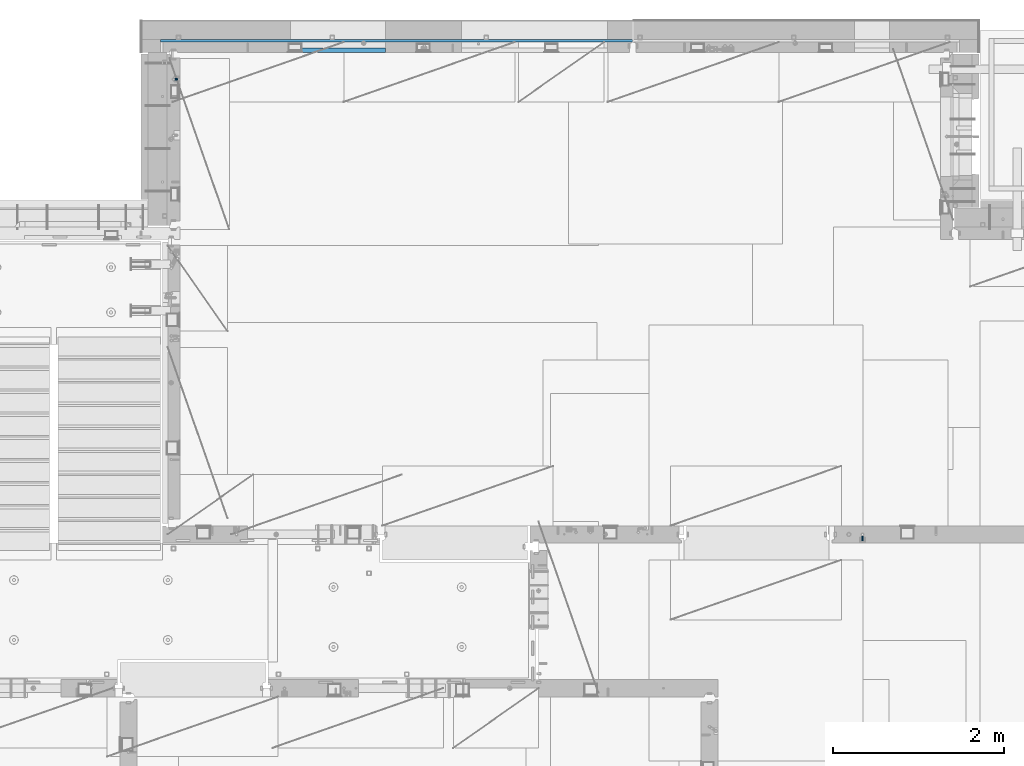
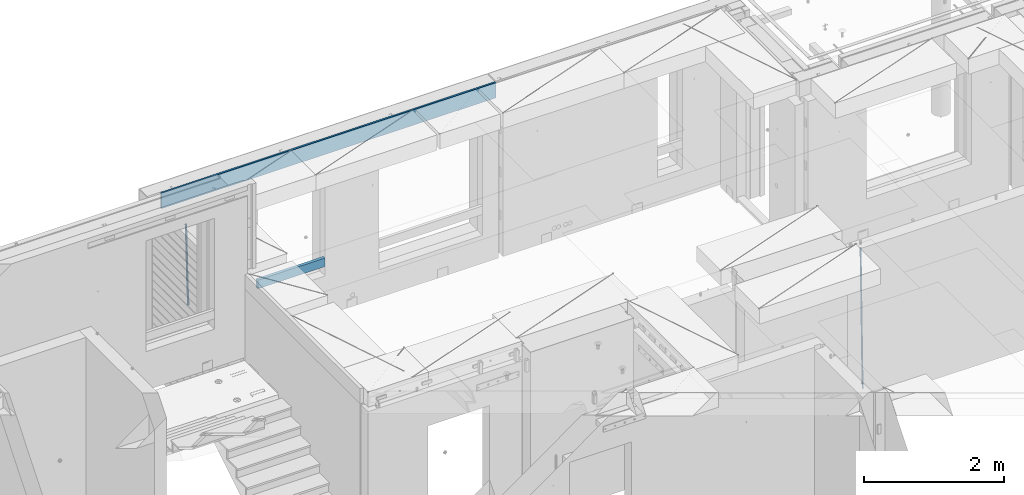
# One storey, part 126 of 349: 4 beams, 3 elements without a shape of their own.
"""IFC2X3 building model written with IfcOpenShell, lengths in millimetres."""

from ifc_helpers import new_model, si_unit, frame, origin_with_axes, place, context, subcontext, project, spatial, faceted_brep, material, type_object, element, aggregate, save


model = new_model("IFC2X3")

# Units and contexts
model_context = context("Model", 3, precision=1e-05, world=origin_with_axes())
body_context = subcontext(model_context, "Body", "Model", "MODEL_VIEW")
ifc_project = project(units=[si_unit("LENGTHUNIT", "METRE", prefix="MILLI"), si_unit("AREAUNIT", "SQUARE_METRE"), si_unit("VOLUMEUNIT", "CUBIC_METRE"), si_unit("MASSUNIT", "GRAM", prefix="KILO"), si_unit("TIMEUNIT", "SECOND"), si_unit("PLANEANGLEUNIT", "RADIAN"), si_unit("SOLIDANGLEUNIT", "STERADIAN"), si_unit("THERMODYNAMICTEMPERATUREUNIT", "DEGREE_CELSIUS"), si_unit("LUMINOUSINTENSITYUNIT", "LUMEN")], contexts=[model_context])

# Site, building, storey
site_placement = place(None, origin_with_axes())
site = spatial("IfcSite", under=ifc_project, at=site_placement, CompositionType="ELEMENT")
building_placement = place(site_placement, origin_with_axes())
building = spatial("IfcBuilding", under=site, at=building_placement, CompositionType="ELEMENT")
storey_placement = place(building_placement, origin_with_axes())
storey = spatial("IfcBuildingStorey", under=building, at=storey_placement, Name="4", CompositionType="ELEMENT", Elevation=0.0)

# Assembly, beam
assembly_1_placement = place(storey_placement, origin_with_axes())
assembly_1 = element("IfcElementAssembly", 1, at=assembly_1_placement, inside=storey, AssemblyPlace="NOTDEFINED", PredefinedType="REINFORCEMENT_UNIT")
ifc_material_1 = material()
beam_type_1 = type_object("IfcBeamType", Name="D20", PredefinedType="NOTDEFINED")
beam_1_placement = place(assembly_1_placement, frame((30400.0000000039, 16915.0002418615, 90990.0), z_axis=(-0.000205762999925498, 0.999642804629538, -0.0267249099901004), x_axis=(4.30000201928125e-08, 0.0267249099948059, 0.999642825806181)))
beam_1 = element("IfcBeam", 2, at=beam_1_placement, type_object=beam_type_1, material=ifc_material_1, Name="JM20", ObjectType="D20", context=body_context, shape_type="Brep", body=[
    faceted_brep([(0.0, -10.0, 0.0), (-4.19531716033816e-08, -7.07106781186667, -7.07106781187031), (60.4266690400545, -7.0710677960451, -7.07106780570757), (60.4266690441291, -9.99999998418934, 6.15546014159918e-09), (0.0, 0.0, -10.0), (60.426669036824, 1.58106558956206e-08, -9.99999999384454), (4.196772351861e-08, 7.07106781186303, -7.07106781186667), (60.4266690363438, 7.07106782768096, -7.07106780570757), (0.0, 10.0, 0.0), (60.4266690388904, 10.0000000158179, 6.15182216279209e-09), (4.196772351861e-08, 7.07106781185939, 7.07106781185939), (60.4266690429649, 7.07106782768096, 7.07106781802577), (0.0, 0.0, 10.0), (60.4266690461809, 1.58179318532348e-08, 10.0000000061555), (-4.19531716033816e-08, -7.07106781187031, 7.07106781185939), (60.4266690466611, -7.07106779605238, 7.07106781802213), (61.0378400410118, -7.07106779588503, -7.07106780564936), (60.991799419251, -9.99999998403655, 6.21366780251265e-09), (61.0569027789461, 1.5985278878361e-08, -9.99999999378269), (61.0378209396877, 7.07106782784831, -7.07106780564936), (60.9917724058905, 10.0000000159635, 6.21366780251265e-09), (60.9457317841297, 7.07106782781193, 7.0710678180767), (60.9266690461809, 1.59488990902901e-08, 10.0000000062028), (60.9457508854539, -7.07106779591413, 7.0710678180767), (61.6489592143771, -7.07106614513759, -7.06310863441468), (61.5568818710308, -9.9999984576425, 0.00735959856683621), (61.6870830769039, 1.71821739058942e-06, -9.99179257185824), (61.6489210170112, 7.07106947854481, -7.06310888312146), (61.556827851804, 10.0000015422847, 0.00735924683976918), (61.4647505084577, 7.07106922979438, 7.07782747982128), (61.4266266459163, 1.36643211590126e-06, 10.0065114172685), (61.464788705809, -7.07106639389531, 7.07782772852806), (176.543135720174, -7.07075579406956, -5.56673531796696), (176.451058376813, -9.99968810657447, 1.50373291501455), (176.581259582701, 0.000312069292704109, -8.49541925541052), (176.543097522794, 7.07137982961285, -5.56673556667374), (176.451004357587, 10.00031189336, 1.50373256329476), (176.35892701424, 7.07137958085514, 8.57420079627263), (176.320803151699, 0.000311717507429421, 11.5028847337162), (176.358965211621, -7.07075604281999, 8.57420104497578), (177.098753836006, -7.07075429323595, -5.55949898843028), (176.98362511232, -9.99968666800123, 1.510669025065), (177.146421932586, 0.000313595905026887, -8.48805862247536), (177.098706077581, 7.07138133041735, -5.55949936166144), (176.983557571715, 10.0003133318824, 1.51066849724157), (176.868428848029, 7.07138095712435, 8.58083651073321), (176.820760751449, 0.000313067976094317, 11.5093961447819), (176.868476606425, -7.07075466652896, 8.58083688396073), (177.654312950661, -7.07075204110879, -5.54863964998367), (177.516135294456, -9.99968450931192, 1.52107783331303), (177.711524267797, 0.000315886711177882, -8.47701274570863), (177.654255632195, 7.07138358250813, -5.54864021007961), (177.516054233929, 10.0003154905207, 1.5210770412159), (177.377876577739, 7.0713830223176, 8.59079452451624), (177.320665260588, 0.000315094497636892, 11.5191676202448), (177.377933896176, -7.07075260129932, 8.59079508461218), (299.499456785634, -7.07025810522464, -3.16697112782276), (299.361279129444, -9.99919057342777, 3.90274635547394), (299.556668102785, 0.000809822595329024, -6.09534422354773), (299.499399467197, 7.07187751838501, -3.1669716879187), (299.361198068917, 10.0008094264049, 3.90274556338045), (299.223020412712, 7.07187695819448, 10.9724630466735), (299.165809095575, 0.000809030381788034, 13.9008361423985), (299.223077731163, -7.07025866542244, 10.9724636067695), (300.03174732349, -7.07025594743027, -3.15656661289177), (299.971788958996, -9.99918809853989, 3.91467979818117), (300.056572611924, 0.000811849109595641, -6.08557274808481), (300.031722507032, 7.07187967631762, -3.15656653768019), (299.971753863239, 10.0008119014747, 3.91467990454839), (299.91179549876, 7.07187975035777, 10.9859263156177), (299.886970210311, 0.000811953817901667, 13.9149324508144), (299.911820315203, -7.0702558733974, 10.9859262404061), (300.564137759997, -7.07025623699155, -3.15794273276697), (300.582413367199, -9.99918843065097, 3.91310145956595), (300.556570941641, 0.000811577163403854, -6.0868651410201), (300.564145451674, 7.07187938674906, -3.15794274158179), (300.582424244858, 10.0008115693345, 3.91310144710224), (300.600699852032, 7.07187937566778, 10.9841456394352), (300.608266670402, 0.000811561512819026, 13.9130680476919), (300.600692160384, -7.07025624805829, 10.98414564825), (2294.16589219622, -7.0713405251372, -8.31099358700158), (2294.1841678034, -10.0002727187966, -1.23994939466866), (2294.15832537785, -0.000272710982244462, -11.2399159952547), (2294.16589988787, 7.07079509858886, -8.31099359582004), (2294.18417868105, 9.99972728118883, -1.23994940713601), (2294.20245428824, 7.07079508752213, 5.83109478519327), (2294.2100211066, -0.00027272663282929, 8.76001719345368), (2294.20244659658, -7.07134053620393, 5.83109479401173), (2294.7782683276, -7.07134085819416, -8.31257645345977), (2294.72126025338, -10.000273010919, -1.24133766827799), (2294.84007459224, -0.000273081772320438, -11.2416781768807), (2294.87047377572, 7.07079471537872, -8.31281477453012), (2294.85165844864, 9.9997269181622, -1.24167470516841), (2294.7946503744, 7.07079476544459, 5.82956408001337), (2294.73284410976, -0.000273010977252852, 8.75866580342336), (2294.7024449263, -7.07134080815013, 5.82980240107645), (2295.39054023061, -7.0793250091956, -8.30442771922026), (2295.25826128852, -10.0072756143927, -1.23419071494573), (2295.52170777075, -0.00916171800054144, -11.2326063125765), (2295.57492774284, 7.06160849139269, -8.30343918807193), (2295.51902460904, 9.99102432676591, -1.23279272078435), (2295.38674566693, 7.06307372157607, 5.83744428349019), (2295.25557812679, -0.0070895696117077, 8.76562287684646), (2295.20235815471, -7.07785977901949, 5.83645575234186), (2317.1947101649, -7.36365585014573, -8.01423575520312), (2317.06243122277, -10.2916064553428, -0.94399875092131), (2317.32587770502, -0.293492558957951, -10.9424143485521), (2317.37909767711, 6.77727765044983, -8.01324722405116), (2317.32319454331, 9.70669348581578, -0.942600756767206), (2317.1909156012, 6.77874288063322, 6.12763624751096), (2317.05974806109, -0.291420410569117, 9.0558148408636), (2317.00652808898, -7.36219061996962, 6.12664771636264), (2317.83015404257, -7.37194216843636, -8.00577862486898), (2317.72252095213, -10.300214160583, -0.935213608652703), (2317.90419832576, -0.301033978277701, -10.9347174723516), (2317.90127966482, 6.77046829039318, -8.00629749759901), (2317.82310777172, 9.70017451494641, -0.935947405505431), (2317.71547468127, 6.77190252279979, 6.13461761071085), (2317.64143039809, -0.29900566735887, 9.06355645819713), (2317.64434905903, -7.37050793602975, 6.13513648344451), (2318.46565174212, -7.3700661537805, -7.99751648408346), (2318.38266643914, -10.2982456018653, -0.926623872735945), (2318.48256818345, -0.299336209594912, -10.9272153854981), (2318.42350634121, 6.77200652527245, -7.99954269419686), (2318.32306384158, 9.70166538090416, -0.929489366557391), (2318.2400785386, 6.77348593281204, 6.14140324480104), (2318.22316209726, -0.297244011366274, 9.07110214621207), (2318.2822239395, -7.36858674623363, 6.1434294549108), (2418.48643733139, -7.07180401323421, -6.70013846199799), (2418.4034520284, -9.99998346132634, 0.370754149349523), (2418.5033537727, -0.00107406904135132, -9.62983736341266), (2418.44429193046, 7.07026866581873, -6.70216467211139), (2418.34384943081, 9.99992752145772, 0.367888655531715), (2418.26086412782, 7.0717480733656, 7.43878126688651), (2418.24394768651, 0.00101812917273492, 10.3684801682975), (2418.30300952874, -7.07032460568735, 7.44080747699627)], [[[0, 1, 2, 3]], [[1, 4, 5, 2]], [[4, 6, 7, 5]], [[6, 8, 9, 7]], [[8, 10, 11, 9]], [[10, 12, 13, 11]], [[12, 14, 15, 13]], [[14, 0, 3, 15]], [[14, 12, 10, 8, 6, 4, 1, 0]], [[3, 2, 16, 17]], [[2, 5, 18, 16]], [[5, 7, 19, 18]], [[7, 9, 20, 19]], [[9, 11, 21, 20]], [[11, 13, 22, 21]], [[13, 15, 23, 22]], [[15, 3, 17, 23]], [[17, 16, 24, 25]], [[16, 18, 26, 24]], [[18, 19, 27, 26]], [[19, 20, 28, 27]], [[20, 21, 29, 28]], [[21, 22, 30, 29]], [[22, 23, 31, 30]], [[23, 17, 25, 31]], [[25, 24, 32, 33]], [[24, 26, 34, 32]], [[26, 27, 35, 34]], [[27, 28, 36, 35]], [[28, 29, 37, 36]], [[29, 30, 38, 37]], [[30, 31, 39, 38]], [[31, 25, 33, 39]], [[33, 32, 40, 41]], [[32, 34, 42, 40]], [[34, 35, 43, 42]], [[35, 36, 44, 43]], [[36, 37, 45, 44]], [[37, 38, 46, 45]], [[38, 39, 47, 46]], [[39, 33, 41, 47]], [[41, 40, 48, 49]], [[40, 42, 50, 48]], [[42, 43, 51, 50]], [[43, 44, 52, 51]], [[44, 45, 53, 52]], [[45, 46, 54, 53]], [[46, 47, 55, 54]], [[47, 41, 49, 55]], [[49, 48, 56, 57]], [[48, 50, 58, 56]], [[50, 51, 59, 58]], [[51, 52, 60, 59]], [[52, 53, 61, 60]], [[53, 54, 62, 61]], [[54, 55, 63, 62]], [[55, 49, 57, 63]], [[57, 56, 64, 65]], [[56, 58, 66, 64]], [[58, 59, 67, 66]], [[59, 60, 68, 67]], [[60, 61, 69, 68]], [[61, 62, 70, 69]], [[62, 63, 71, 70]], [[63, 57, 65, 71]], [[65, 64, 72, 73]], [[64, 66, 74, 72]], [[66, 67, 75, 74]], [[67, 68, 76, 75]], [[68, 69, 77, 76]], [[69, 70, 78, 77]], [[70, 71, 79, 78]], [[71, 65, 73, 79]], [[73, 72, 80, 81]], [[72, 74, 82, 80]], [[74, 75, 83, 82]], [[75, 76, 84, 83]], [[76, 77, 85, 84]], [[77, 78, 86, 85]], [[78, 79, 87, 86]], [[79, 73, 81, 87]], [[81, 80, 88, 89]], [[80, 82, 90, 88]], [[82, 83, 91, 90]], [[83, 84, 92, 91]], [[84, 85, 93, 92]], [[85, 86, 94, 93]], [[86, 87, 95, 94]], [[87, 81, 89, 95]], [[89, 88, 96, 97]], [[88, 90, 98, 96]], [[90, 91, 99, 98]], [[91, 92, 100, 99]], [[92, 93, 101, 100]], [[93, 94, 102, 101]], [[94, 95, 103, 102]], [[95, 89, 97, 103]], [[97, 96, 104, 105]], [[96, 98, 106, 104]], [[98, 99, 107, 106]], [[99, 100, 108, 107]], [[100, 101, 109, 108]], [[101, 102, 110, 109]], [[102, 103, 111, 110]], [[103, 97, 105, 111]], [[105, 104, 112, 113]], [[104, 106, 114, 112]], [[106, 107, 115, 114]], [[107, 108, 116, 115]], [[108, 109, 117, 116]], [[109, 110, 118, 117]], [[110, 111, 119, 118]], [[111, 105, 113, 119]], [[113, 112, 120, 121]], [[112, 114, 122, 120]], [[114, 115, 123, 122]], [[115, 116, 124, 123]], [[116, 117, 125, 124]], [[117, 118, 126, 125]], [[118, 119, 127, 126]], [[119, 113, 121, 127]], [[121, 120, 128, 129]], [[120, 122, 130, 128]], [[122, 123, 131, 130]], [[123, 124, 132, 131]], [[124, 125, 133, 132]], [[125, 126, 134, 133]], [[126, 127, 135, 134]], [[127, 121, 129, 135]], [[130, 131, 132, 133, 134, 135, 129, 128]]]),
])
aggregate(assembly_1, [beam_1])

assembly_2_placement = place(storey_placement, origin_with_axes())
assembly_2 = element("IfcElementAssembly", 3, at=assembly_2_placement, inside=storey, AssemblyPlace="NOTDEFINED", PredefinedType="REINFORCEMENT_UNIT")
beam_type_2 = type_object("IfcBeamType", Name="D25", PredefinedType="NOTDEFINED")
beam_2_placement = place(assembly_2_placement, frame((22375.0000022791, 22307.0000022831, 91990.0), z_axis=(-0.999642804636942, -0.000205726999925762, -0.0267249099902983), x_axis=(-0.0267249099948371, 4.30000201934385e-08, 0.999642825806181)))
beam_2 = element("IfcBeam", 4, at=beam_2_placement, type_object=beam_type_2, material=ifc_material_1, Name="JM25", ObjectType="D25", context=body_context, shape_type="Brep", body=[
    faceted_brep([(-7.41420080885291e-08, -12.5, -3.63797880709171e-12), (-6.42030499875546e-08, -10.8253175473074, -6.25000000000364), (60.4103898235917, -10.8253175318459, -6.2499999938409), (60.4103898269532, -12.4999999845422, 6.16273609921336e-09), (-3.70782800018787e-08, -6.25000000000364, -10.8253175473074), (60.4103898202884, -6.24999998454587, -10.8253175411446), (-1.45519152283669e-11, -3.63797880709171e-12, -12.5), (60.4103898179019, 1.54577719513327e-08, -12.4999999938373), (3.70637280866504e-08, 6.25, -10.8253175473074), (60.410389817087, 6.25000001545777, -10.825317541141), (6.42030499875546e-08, 10.8253175473001, -6.25000000000364), (60.410389818062, 10.8253175627578, -6.24999999383726), (7.41420080885291e-08, 12.4999999999927, 0.0), (60.4103898205503, 12.5000000154541, 6.16273609921336e-09), (6.42176019027829e-08, 10.8253175473001, 6.24999999999636), (60.4103898238973, 10.8253175627651, 6.2500000061591), (3.70928319171071e-08, 6.24999999999636, 10.8253175473037), (60.4103898272151, 6.25000001546141, 10.8253175534664), (1.45519152283669e-11, -3.63797880709171e-12, 12.4999999999964), (60.4103898296162, 1.54541339725256e-08, 12.5000000061591), (-3.7049176171422e-08, -6.25000000000364, 10.8253175473001), (60.4103898304165, -6.24999998454587, 10.8253175534701), (-6.41884980723262e-08, -10.8253175473074, 6.25), (60.4103898294561, -10.8253175318459, 6.25000000616637), (61.0324985728803, -10.8253175316895, -6.24999999377542), (60.991802792938, -12.4999999843931, 6.22458173893392e-09), (61.0622854283865, -6.24999998437852, -10.8253175410755), (61.0731819955545, 1.5628756955266e-08, -12.4999999937718), (61.0622685480339, 6.25000001562512, -10.8253175410791), (61.032469335245, 10.8253175629216, -6.24999999377178), (60.9917690322181, 12.5000000156033, 6.22458173893392e-09), (60.9510732522613, 10.8253175629034, 6.25000000621731), (60.9212863967696, 6.25000001558874, 10.8253175535247), (60.9103898296162, 1.55814632307738e-08, 12.5000000062137), (60.9213032771368, -6.24999998441126, 10.8253175535174), (60.9511024898966, -10.8253175317113, 6.25000000621731), (61.6545545670233, -10.8253158516927, -6.24189838219536), (61.573166454793, -12.499998414296, 0.00757164385504439), (61.7141257553885, -6.24999822394238, -10.8168280205282), (61.7359179680789, 1.80548886419274e-06, -12.491368569139), (61.7140919992817, 6.25000177601396, -10.8168282403167), (61.6544960997562, 10.8253192428383, -6.2418987628771), (61.5730989426083, 12.5000015856094, 0.0075712042817031), (61.4917108303925, 10.8253190230062, 6.25704123032847), (61.4321396420273, 6.25000139525582, 10.8319708686649), (61.4103474293224, 1.36582457344048e-06, 12.5065114172721), (61.4321733981196, -6.24999860470052, 10.8319710884571), (61.4917692976451, -10.8253160715249, 6.25704161101385), (176.524302641745, -10.8250056210964, -4.74584321979273), (176.442914529529, -12.4996881836996, 1.50362680625403), (176.583873830095, -6.24968799334965, -9.3207728581292), (176.605666042786, 0.000312036081595579, -10.9953134067364), (176.583840074018, 6.25031200660669, -9.32077307791769), (176.524244174492, 10.8256294734347, -4.74584360047811), (176.44284701733, 12.5003118162058, 1.50362636668069), (176.361458905099, 10.8256292535989, 7.75309639272746), (176.301887716749, 6.25031162585219, 12.3280260310676), (176.280095504058, 0.000311596420942806, 14.0025665796711), (176.301921472827, -6.24968837410415, 12.3280262508561), (176.361517372367, -10.8250058409321, 7.75309677341284), (177.085397012124, -10.8250041057399, -4.73853556792164), (176.983633547483, -12.4996867233749, 1.51066909103247), (177.159881729676, -6.24968643771717, -9.31327097355097), (177.187129580227, 0.000313606451527448, -10.987740468332), (177.159839524218, 6.25031356221734, -9.31327130338468), (177.085323910098, 10.8256309887511, -4.73853613920801), (176.983549136537, 12.5003132764905, 1.51066843136869), (176.881785671867, 10.8256306588555, 7.7598730903228), (176.80730095433, 6.25031299082912, 12.3346084959521), (176.780053103794, 0.000312946667690994, 14.0090779907332), (176.807343159802, -6.2496870091054, 12.3346088257895), (176.881858773908, -10.8250044356355, 7.7598736616128), (177.646431799818, -10.8250018318176, -4.72756919822132), (177.524295146417, -12.4996845320202, 1.52123723245313), (177.735828462886, -6.24968410334986, -9.30201312475765), (177.768531371941, 0.00031596292683389, -10.9763759912421), (177.735777808921, 6.25031589654827, -9.30201361973741), (177.646344064575, 10.8256332626152, -4.72757005553649), (177.524193838486, 12.5003154677688, 1.52123624250817), (177.402057185071, 10.8256327675663, 7.77004267317898), (177.312660521988, 6.2503150390985, 12.3444865997226), (177.279957612933, 0.00031497282179771, 14.0188494661961), (177.312711175953, -6.24968496079964, 12.3444870946951), (177.402144920314, -10.8250023268702, 7.77004353049415), (299.450416306776, -10.8245081491878, -2.34670520440704), (299.32827965336, -12.4991908493976, 3.9021012262674), (299.539812969844, -6.24919042071997, -6.92114913095065), (299.572515878914, 0.000809645553090377, -8.59551199742418), (299.539762315893, 6.25080957917817, -6.9211496259195), (299.450328571547, 10.8261269452451, -2.34670606172585), (299.328178345429, 12.5008091504023, 3.9021002363188), (299.206041692043, 10.8261264501925, 10.1509066669969), (299.11664502896, 6.25080872172475, 14.7253505935405), (299.083942119891, 0.000808655455330154, 16.3997134600104), (299.116695682911, -6.24919127817338, 14.7253510885093), (299.206129427272, -10.8245086442366, 10.1509075243121), (300.022114107283, -10.8245058320463, -2.33553040816332), (299.97179243555, -12.4991882411778, 3.91467976726199), (300.058946494231, -6.24918831662217, -6.9110017919993), (300.072420388053, 0.000811671710835071, -8.58574052196127), (300.058925469799, 6.25081168339239, -6.91100170781283), (300.022077691901, 10.8261292625939, -2.33553026234586), (299.971750386685, 12.5008117588586, 3.91467993563856), (299.921428714966, 10.8261293497235, 10.1648901110639), (299.884596327989, 6.25081183430666, 14.7403614948998), (299.871122434168, 0.000811845966381952, 16.4151002248582), (299.884617352436, -6.24918816571881, 14.7403614107134), (299.921465130334, -10.8245057449167, 10.1648899652428), (300.593917726728, -10.8245062259339, -2.33749813354007), (300.615424329342, -12.4991886845492, 3.91246486206001), (300.578176108116, -6.24918867429733, -6.91278859651356), (300.572417427509, 0.00081132728519151, -8.58746114217138), (300.578184718717, 6.25081132569903, -6.91278861431056), (300.59393264071, 10.8261288686736, -2.33749816436102), (300.615441550515, 12.5008113154472, 3.91246482646966), (300.636948153115, 10.8261288568356, 10.1624278220661), (300.652689771727, 6.25081130520266, 14.7377182850432), (300.658448452334, 0.000811303612863412, 16.4123908306974), (300.65268116114, -6.24918869479734, 14.7377183028366), (300.636933239148, -10.8245062377719, 10.162427852887), (1293.8225958722, -10.8251904135213, -5.7554570479515), (1293.84410247482, -12.4998728721366, 0.494505947652215), (1293.80685425361, -6.2498728618848, -10.330747510925), (1293.801095573, 0.000127139694086509, -12.0054200565755), (1293.80686286419, 6.25012713810793, -10.3307475287183), (1293.82261078618, 10.8254446810788, -5.75545707877609), (1293.84411969599, 12.5001271278561, 0.49450591205823), (1293.86562629859, 10.8254446692445, 6.7444689076583), (1293.8813679172, 6.25012711760428, 11.3197593706318), (1293.88712659782, 0.00012711602539639, 12.994431916286), (1293.88135930662, -6.24987288238844, 11.3197593884252), (1293.86561138462, -10.8251904253593, 6.7444689384829), (1294.43576264779, -10.8251908359052, -5.75756711474241), (1294.39401066334, -12.4998732509448, 0.492613570157118), (1294.4881651176, -6.24987333120953, -10.3330920792978), (1294.53717687333, 0.000126632643514313, -12.0079531043048), (1294.56966525462, 6.25012661264918, -10.3333725306838), (1294.5769250259, 10.8254441614699, -5.75805287079493), (1294.55701093735, 12.5001266367835, 0.492052667374082), (1294.51525895292, 10.825444221744, 6.74223335227362), (1294.46285648308, 6.25012671704826, 11.3177583168253), (1294.41384472734, 0.000126753191580065, 12.9926193418323), (1294.38135634607, -6.24987322681045, 11.318038768215), (1294.37409657479, -10.8251907756348, 6.74271910832613), (1295.04882664244, -10.8331853159034, -5.74940783883358), (1294.94382667454, -12.5070429642874, 0.499931077909423), (1295.16936177819, -6.25875627512141, -10.3240260249331), (1295.27313478947, -0.00947040924438625, -11.9981582317523), (1295.33233978174, 6.24018118068125, -10.3232220864411), (1295.33111282514, 10.8156093981706, -5.74801537651729), (1295.26978268167, 12.4908319473179, 0.501538954897114), (1295.16478271378, 10.8169742989339, 6.75087787164011), (1295.04424757806, 6.24254525814467, 11.3254960577397), (1294.94047456676, -0.00674060772507801, 12.9996282645552), (1294.88126957447, -6.25639219765071, 11.3246921192476), (1294.88249653111, -10.8318204151437, 6.74948540932019), (1316.80386422646, -11.116875459662, -5.45986978806832), (1316.69886425855, -12.790733108046, 0.789469128674682), (1316.92439936219, -6.54244641887635, -10.0344879741715), (1317.02817237348, -0.293160553006601, -11.7086201809871), (1317.08737736575, 5.95649103692267, -10.0336840356795), (1317.08615040916, 10.5319192544084, -5.45847732575203), (1317.02482026568, 12.2071418035557, 0.791077005658735), (1316.91982029779, 10.5332841551717, 7.0404159223981), (1316.79928516207, 5.9588551143861, 11.6150341085013), (1316.69551215076, -0.290430751483655, 13.2891663153168), (1316.63630715849, -6.54008234141656, 11.6142301700129), (1316.6375341151, -11.1155105589023, 7.03902346008545), (1317.48953548315, -11.1258167532178, -5.45074418126023), (1317.39899812841, -12.7998629970425, 0.798787218573125), (1317.57265877169, -6.55089985429368, -10.0258602820722), (1317.62609517592, -0.300957588759047, -11.7006624193855), (1317.63552645453, 5.94934306058713, -10.0263887130131), (1317.59842550401, 10.5252390823007, -5.4516594505003), (1317.52473349411, 12.2006228327155, 0.79773035668768), (1317.43419613934, 10.5265765888907, 7.0472617565174), (1317.35107285083, 5.95165968996662, 11.6223778573367), (1317.2976364466, -0.29828257556801, 13.2971799946463), (1317.28820516799, -6.54858322491418, 11.6229062882776), (1317.32530611851, -11.1244792466277, 7.04817702575747), (1318.17526469367, -11.1237887330935, -5.44182040245869), (1318.09919107273, -12.797775016028, 0.807903115066438), (1318.22097315147, -6.5489957269856, -10.0174341323618), (1318.22406890181, -0.299208089221793, -11.6929060708244), (1318.18372244084, 5.95094862978294, -10.0192948650074), (1318.11074457024, 10.526749984605, -5.44504328594121), (1318.02468965146, 12.2021136975018, 0.804181649778911), (1317.94861603052, 10.52812741456, 7.05390516730768), (1317.90290757272, 5.95333440845207, 11.6295188972072), (1317.8998118224, -0.296453229308099, 13.3049908356734), (1317.94015828335, -6.54660994831283, 11.6313796298491), (1318.01313615397, -11.1224113031385, 7.0571280507902), (1418.17602640855, -10.8255863639497, -4.14470589025586), (1418.09995278763, -12.4995726468842, 2.10501762727654), (1418.22173486637, -6.25079335783812, -8.72031962014808), (1418.2248306167, -0.00100572007431765, -10.3957915586216), (1418.18448415573, 6.24915099893042, -8.72218035279366), (1418.11150628512, 10.8249523537488, -4.14792877373111), (1418.02545136634, 12.500316066642, 2.10129616199265), (1417.94937774542, 10.8263297837075, 8.35101967951414), (1417.90366928761, 6.2515367775959, 12.9266334094173), (1417.90057353729, 0.00174913983573788, 14.6021053478798), (1417.94091999825, -6.248407579169, 12.9284941420592), (1418.01389786886, -10.824208933991, 8.35424256299666)], [[[0, 1, 2, 3]], [[1, 4, 5, 2]], [[4, 6, 7, 5]], [[6, 8, 9, 7]], [[8, 10, 11, 9]], [[10, 12, 13, 11]], [[12, 14, 15, 13]], [[14, 16, 17, 15]], [[16, 18, 19, 17]], [[18, 20, 21, 19]], [[20, 22, 23, 21]], [[22, 0, 3, 23]], [[22, 20, 18, 16, 14, 12, 10, 8, 6, 4, 1, 0]], [[3, 2, 24, 25]], [[2, 5, 26, 24]], [[5, 7, 27, 26]], [[7, 9, 28, 27]], [[9, 11, 29, 28]], [[11, 13, 30, 29]], [[13, 15, 31, 30]], [[15, 17, 32, 31]], [[17, 19, 33, 32]], [[19, 21, 34, 33]], [[21, 23, 35, 34]], [[23, 3, 25, 35]], [[25, 24, 36, 37]], [[24, 26, 38, 36]], [[26, 27, 39, 38]], [[27, 28, 40, 39]], [[28, 29, 41, 40]], [[29, 30, 42, 41]], [[30, 31, 43, 42]], [[31, 32, 44, 43]], [[32, 33, 45, 44]], [[33, 34, 46, 45]], [[34, 35, 47, 46]], [[35, 25, 37, 47]], [[37, 36, 48, 49]], [[36, 38, 50, 48]], [[38, 39, 51, 50]], [[39, 40, 52, 51]], [[40, 41, 53, 52]], [[41, 42, 54, 53]], [[42, 43, 55, 54]], [[43, 44, 56, 55]], [[44, 45, 57, 56]], [[45, 46, 58, 57]], [[46, 47, 59, 58]], [[47, 37, 49, 59]], [[49, 48, 60, 61]], [[48, 50, 62, 60]], [[50, 51, 63, 62]], [[51, 52, 64, 63]], [[52, 53, 65, 64]], [[53, 54, 66, 65]], [[54, 55, 67, 66]], [[55, 56, 68, 67]], [[56, 57, 69, 68]], [[57, 58, 70, 69]], [[58, 59, 71, 70]], [[59, 49, 61, 71]], [[61, 60, 72, 73]], [[60, 62, 74, 72]], [[62, 63, 75, 74]], [[63, 64, 76, 75]], [[64, 65, 77, 76]], [[65, 66, 78, 77]], [[66, 67, 79, 78]], [[67, 68, 80, 79]], [[68, 69, 81, 80]], [[69, 70, 82, 81]], [[70, 71, 83, 82]], [[71, 61, 73, 83]], [[73, 72, 84, 85]], [[72, 74, 86, 84]], [[74, 75, 87, 86]], [[75, 76, 88, 87]], [[76, 77, 89, 88]], [[77, 78, 90, 89]], [[78, 79, 91, 90]], [[79, 80, 92, 91]], [[80, 81, 93, 92]], [[81, 82, 94, 93]], [[82, 83, 95, 94]], [[83, 73, 85, 95]], [[85, 84, 96, 97]], [[84, 86, 98, 96]], [[86, 87, 99, 98]], [[87, 88, 100, 99]], [[88, 89, 101, 100]], [[89, 90, 102, 101]], [[90, 91, 103, 102]], [[91, 92, 104, 103]], [[92, 93, 105, 104]], [[93, 94, 106, 105]], [[94, 95, 107, 106]], [[95, 85, 97, 107]], [[97, 96, 108, 109]], [[96, 98, 110, 108]], [[98, 99, 111, 110]], [[99, 100, 112, 111]], [[100, 101, 113, 112]], [[101, 102, 114, 113]], [[102, 103, 115, 114]], [[103, 104, 116, 115]], [[104, 105, 117, 116]], [[105, 106, 118, 117]], [[106, 107, 119, 118]], [[107, 97, 109, 119]], [[109, 108, 120, 121]], [[108, 110, 122, 120]], [[110, 111, 123, 122]], [[111, 112, 124, 123]], [[112, 113, 125, 124]], [[113, 114, 126, 125]], [[114, 115, 127, 126]], [[115, 116, 128, 127]], [[116, 117, 129, 128]], [[117, 118, 130, 129]], [[118, 119, 131, 130]], [[119, 109, 121, 131]], [[121, 120, 132, 133]], [[120, 122, 134, 132]], [[122, 123, 135, 134]], [[123, 124, 136, 135]], [[124, 125, 137, 136]], [[125, 126, 138, 137]], [[126, 127, 139, 138]], [[127, 128, 140, 139]], [[128, 129, 141, 140]], [[129, 130, 142, 141]], [[130, 131, 143, 142]], [[131, 121, 133, 143]], [[133, 132, 144, 145]], [[132, 134, 146, 144]], [[134, 135, 147, 146]], [[135, 136, 148, 147]], [[136, 137, 149, 148]], [[137, 138, 150, 149]], [[138, 139, 151, 150]], [[139, 140, 152, 151]], [[140, 141, 153, 152]], [[141, 142, 154, 153]], [[142, 143, 155, 154]], [[143, 133, 145, 155]], [[145, 144, 156, 157]], [[144, 146, 158, 156]], [[146, 147, 159, 158]], [[147, 148, 160, 159]], [[148, 149, 161, 160]], [[149, 150, 162, 161]], [[150, 151, 163, 162]], [[151, 152, 164, 163]], [[152, 153, 165, 164]], [[153, 154, 166, 165]], [[154, 155, 167, 166]], [[155, 145, 157, 167]], [[157, 156, 168, 169]], [[156, 158, 170, 168]], [[158, 159, 171, 170]], [[159, 160, 172, 171]], [[160, 161, 173, 172]], [[161, 162, 174, 173]], [[162, 163, 175, 174]], [[163, 164, 176, 175]], [[164, 165, 177, 176]], [[165, 166, 178, 177]], [[166, 167, 179, 178]], [[167, 157, 169, 179]], [[169, 168, 180, 181]], [[168, 170, 182, 180]], [[170, 171, 183, 182]], [[171, 172, 184, 183]], [[172, 173, 185, 184]], [[173, 174, 186, 185]], [[174, 175, 187, 186]], [[175, 176, 188, 187]], [[176, 177, 189, 188]], [[177, 178, 190, 189]], [[178, 179, 191, 190]], [[179, 169, 181, 191]], [[181, 180, 192, 193]], [[180, 182, 194, 192]], [[182, 183, 195, 194]], [[183, 184, 196, 195]], [[184, 185, 197, 196]], [[185, 186, 198, 197]], [[186, 187, 199, 198]], [[187, 188, 200, 199]], [[188, 189, 201, 200]], [[189, 190, 202, 201]], [[190, 191, 203, 202]], [[191, 181, 193, 203]], [[194, 195, 196, 197, 198, 199, 200, 201, 202, 203, 193, 192]]]),
])
aggregate(assembly_2, [beam_2])

# Assembly, beams
assembly_3_placement = place(storey_placement, origin_with_axes())
assembly_3 = element("IfcElementAssembly", 5, at=assembly_3_placement, inside=storey, AssemblyPlace="NOTDEFINED", PredefinedType="REINFORCEMENT_UNIT")
ifc_material_2 = material(Name="TIMBER/T24")
beam_type_3 = type_object("IfcBeamType", PredefinedType="NOTDEFINED")
beam_3_placement = place(assembly_3_placement, frame((24815.0002989914, 22644.9998418812, 91685.0), z_axis=(0.0, 0.0, 1.0), x_axis=(-1.0, 3.00000001838171e-08, 0.0)))
beam_3 = element("IfcBeam", 6, at=beam_3_placement, type_object=beam_type_3, material=ifc_material_2, context=body_context, shape_type="Brep", body=[
    faceted_brep([(-3.63797880709171e-12, 24.9999999999964, -75.0), (-3.63797880709171e-12, 24.9999999999964, 75.0), (1110.0, 24.9999999999964, 75.0), (1110.0, 24.9999999999964, -75.0), (0.0, -25.0000000000073, 75.0), (1110.0, -25.0000000000073, 75.0), (0.0, -25.0000000000073, -75.0), (1110.0, -25.0000000000073, -75.0)], [[[0, 1, 2, 3]], [[1, 4, 5, 2]], [[4, 6, 7, 5]], [[6, 0, 3, 7]], [[5, 7, 3, 2]], [[6, 4, 1, 0]]]),
])
ifc_material_3 = material(Name="CONCRETE/C25/30")
beam_type_4 = type_object("IfcBeamType", Name="270X30", PredefinedType="NOTDEFINED")
beam_4_placement = place(assembly_3_placement, frame((27705.0, 22755.0, 93605.0), z_axis=(0.0, 0.0, 1.0), x_axis=(-1.0, 3.00000001838171e-08, 0.0)))
beam_4 = element("IfcBeam", 7, at=beam_4_placement, type_object=beam_type_4, material=ifc_material_3, ObjectType="270X30", context=body_context, shape_type="Brep", body=[
    faceted_brep([(0.0, 15.0, -135.0), (0.0, 15.0, 135.0), (5520.00000000003, 15.0, 135.0), (5520.00000000003, 15.0, -135.0), (0.0, -15.0, 135.0), (5520.00000000003, -15.0, 135.0), (0.0, -15.0, -135.0), (5520.00000000003, -15.0, -135.0)], [[[0, 1, 2, 3]], [[1, 4, 5, 2]], [[4, 6, 7, 5]], [[6, 0, 3, 7]], [[5, 7, 3, 2]], [[6, 4, 1, 0]]]),
])
aggregate(assembly_3, [beam_4, beam_3])

save(model, "model.ifc")
